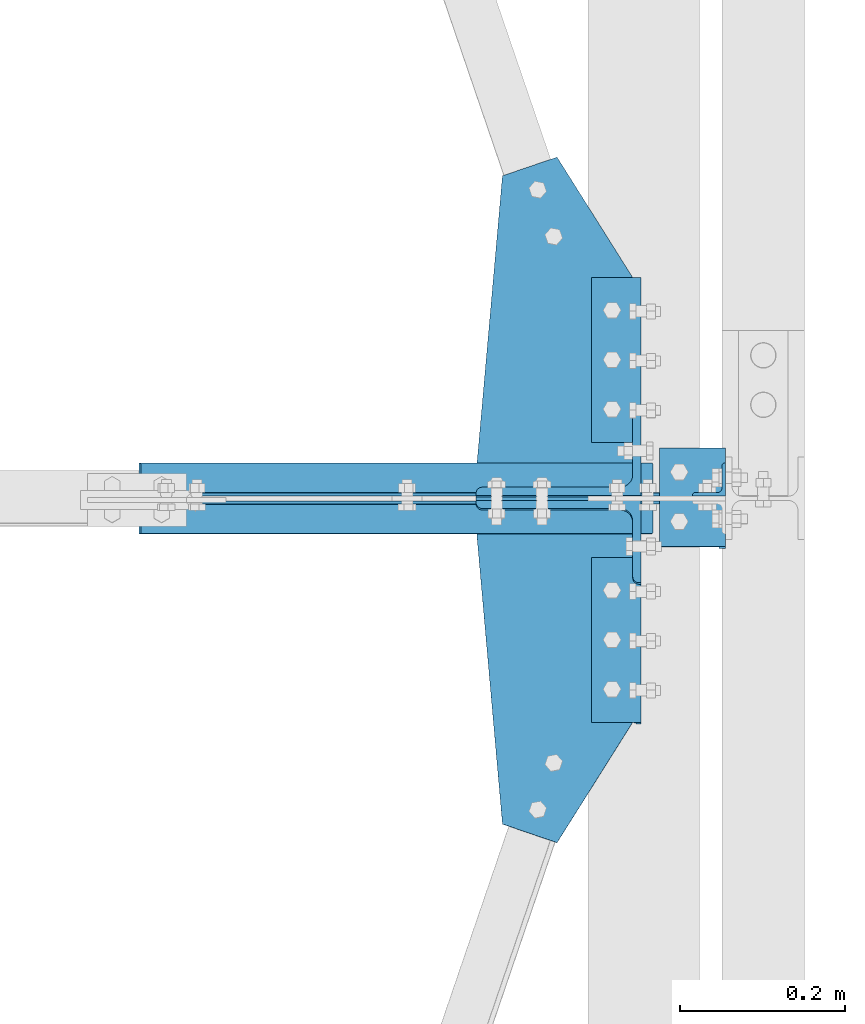
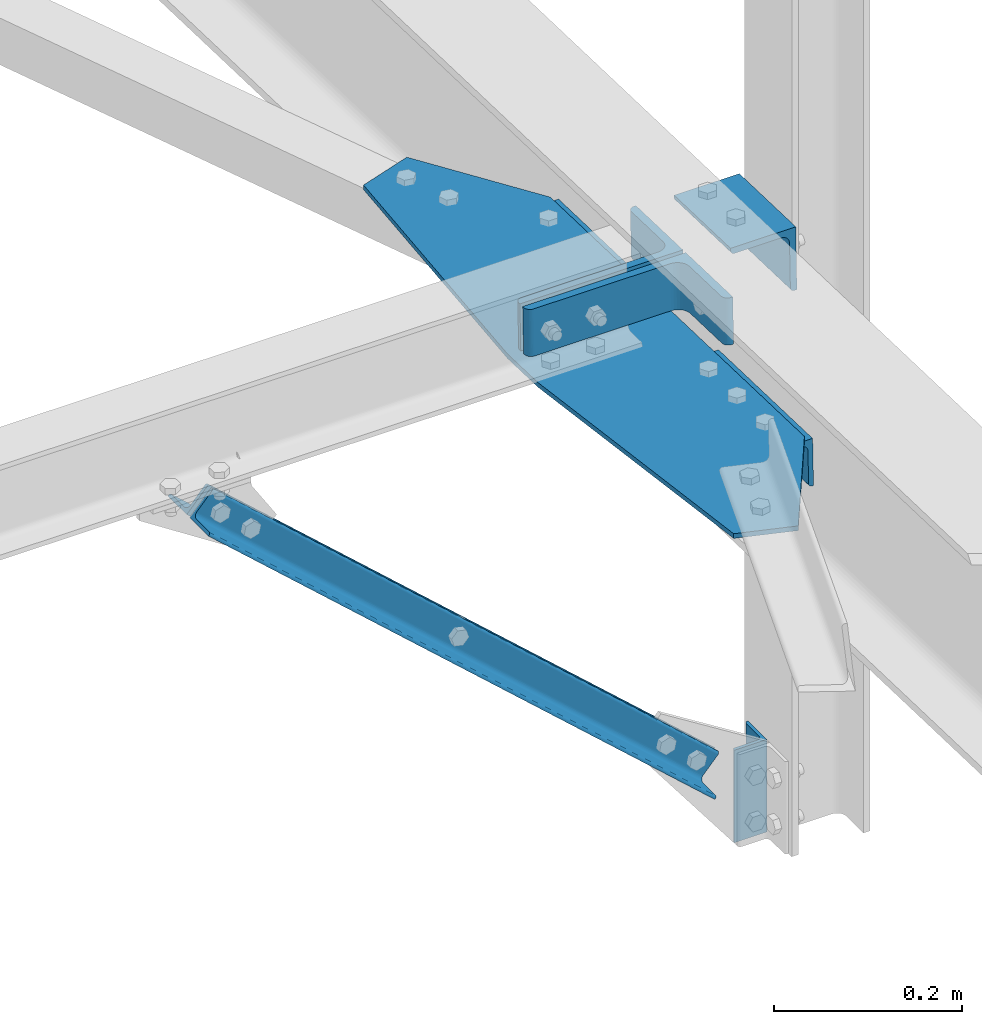
# One storey, part 107 of 496: 5 beams, 4 members, 9 elements without a shape of their own.
"""IFC2X3 building model written with IfcOpenShell, lengths in millimetres."""

import ifcopenshell
import ifcopenshell.guid

model = None  # the IFC model being written
_history = None  # IfcOwnerHistory: only IFC2X3 demands one
_inside = {}  # id of a spatial element -> (the spatial element, [elements in it])
_under = {}  # id of a project, library or spatial element -> (it, [spatial elements below it])
_declared = {}  # id of a project -> (the project, [libraries it declares])
_typed = {}  # id of a type object -> (the type object, [elements of that type])
_made_of = {}  # id of a material, layer set ... -> (it, [elements and type objects made of it])


def new_model(schema):
    """Start an empty IFC model of exactly this schema.

    Asked for "IFC4X3", IfcOpenShell would pick the latest addendum, in which some entities
    have other attributes; the version numbers below select the first issue.
    IFC2X3 requires an IfcOwnerHistory on every rooted entity: one is made here for all.
    """
    global model, _history
    if schema == "IFC4X3":
        model = ifcopenshell.file(schema_version=(4, 3, 0, 0))
    else:
        model = ifcopenshell.file(schema=schema)
    _inside.clear()
    _under.clear()
    _declared.clear()
    _typed.clear()
    _made_of.clear()
    _history = None
    if model.schema == "IFC2X3":
        org = make("IfcOrganization", Name="unknown")
        user = make(
            "IfcPersonAndOrganization",
            ThePerson=make("IfcPerson", FamilyName="unknown"),
            TheOrganization=org,
        )
        app = make(
            "IfcApplication",
            ApplicationDeveloper=org,
            Version="unknown",
            ApplicationFullName="unknown",
            ApplicationIdentifier="unknown",
        )
        _history = make(
            "IfcOwnerHistory",
            OwningUser=user,
            OwningApplication=app,
            ChangeAction="ADDED",
            CreationDate=0,
        )
    return model


def make(cls, **values):
    """One entity of the class cls with the attributes given. An attribute that is None is left unset."""
    return model.create_entity(
        cls, **{name: value for name, value in values.items() if value is not None}
    )


def rooted(cls, **values):
    """An entity with a GlobalId (a new one), such as an element, a storey or a relation."""
    return make(cls, GlobalId=ifcopenshell.guid.new(), OwnerHistory=_history, **values)


def si_unit(unit_type, name, prefix=None):
    """IfcSIUnit, for example si_unit("LENGTHUNIT", "METRE", prefix="MILLI")."""
    return make("IfcSIUnit", UnitType=unit_type, Prefix=prefix, Name=name)


def assignment(units):
    """IfcUnitAssignment: the units of a project."""
    return None if units is None else make("IfcUnitAssignment", Units=units)


def point(xyz):
    """IfcCartesianPoint."""
    return None if xyz is None else make("IfcCartesianPoint", Coordinates=xyz)


def direction(xyz):
    """IfcDirection."""
    return None if xyz is None else make("IfcDirection", DirectionRatios=xyz)


def frame(location, z_axis=None, x_axis=None):
    """IfcAxis2Placement3D, a coordinate frame: its origin and axes. An axis left out is left unset."""
    return make(
        "IfcAxis2Placement3D",
        Location=point(location),
        Axis=direction(z_axis),
        RefDirection=direction(x_axis),
    )


def frame_2d(location, x_axis=None):
    """IfcAxis2Placement2D, a coordinate frame in the plane: its origin and x axis."""
    return make(
        "IfcAxis2Placement2D", Location=point(location), RefDirection=direction(x_axis)
    )


def origin_with_axes():
    """The frame at (0, 0, 0) with the z axis (0, 0, 1) and the x axis (1, 0, 0) written out."""
    return frame((0.0, 0.0, 0.0), z_axis=(0.0, 0.0, 1.0), x_axis=(1.0, 0.0, 0.0))


def origin_2d_with_axis():
    """The frame at (0, 0) in the plane with the x axis (1, 0) written out."""
    return frame_2d((0.0, 0.0), x_axis=(1.0, 0.0))


def place(relative_to, where):
    """IfcLocalPlacement: puts the frame where relative to a parent placement (None: the world)."""
    return make(
        "IfcLocalPlacement", PlacementRelTo=relative_to, RelativePlacement=where
    )


def context(
    kind, dimensions, precision=None, world=None, true_north=None, identifier=None
):
    """IfcGeometricRepresentationContext, for example the 3D "Model" context."""
    return make(
        "IfcGeometricRepresentationContext",
        ContextIdentifier=identifier,
        ContextType=kind,
        CoordinateSpaceDimension=dimensions,
        Precision=precision,
        WorldCoordinateSystem=world,
        TrueNorth=true_north,
    )


def subcontext(parent, identifier, kind, view, scale=None):
    """IfcGeometricRepresentationSubContext, for example "Body" below "Model"."""
    return make(
        "IfcGeometricRepresentationSubContext",
        ContextIdentifier=identifier,
        ContextType=kind,
        ParentContext=parent,
        TargetScale=scale,
        TargetView=view,
    )


def project(units=None, contexts=None):
    """IfcProject with its units and contexts."""
    return rooted(
        "IfcProject",
        Name="project",
        RepresentationContexts=contexts,
        UnitsInContext=assignment(units),
    )


def spatial(cls, under=None, at=None, **own):
    """A site, building, storey or space (cls), placed at a placement, below another one or the project."""
    s = rooted(cls, ObjectPlacement=at, **own)
    if under is not None:
        _under.setdefault(under.id(), (under, []))[1].append(s)
    return s


def polyline(points):
    """IfcPolyline through the points."""
    return make("IfcPolyline", Points=[point(p) for p in points])


def profile(cls, at=None, kind="AREA", **sizes):
    """A parametric profile (cls). Its sizes go by their IFC names, for example OverallWidth=200.0."""
    return make(cls, ProfileType=kind, Position=at, **sizes)


def l_section(**sizes):
    """IfcLShapeProfileDef."""
    return profile("IfcLShapeProfileDef", **sizes)


def outline(outer, holes=None, kind="AREA"):
    """IfcArbitraryClosedProfileDef: a profile drawn as a closed curve; with holes, ...WithVoids."""
    if holes is None:
        return make("IfcArbitraryClosedProfileDef", ProfileType=kind, OuterCurve=outer)
    return make(
        "IfcArbitraryProfileDefWithVoids",
        ProfileType=kind,
        OuterCurve=outer,
        InnerCurves=holes,
    )


def extrude(swept, where, along, depth):
    """IfcExtrudedAreaSolid: the profile swept, set in the frame where, extruded along a direction by depth."""
    return make(
        "IfcExtrudedAreaSolid",
        SweptArea=swept,
        Position=where,
        ExtrudedDirection=direction(along),
        Depth=depth,
    )


def clip(a, b, op="DIFFERENCE"):
    """IfcBooleanClippingResult: the solid a cut by the half space b."""
    return make(
        "IfcBooleanClippingResult", Operator=op, FirstOperand=a, SecondOperand=b
    )


def halfspace(plane, agree):
    """IfcHalfSpaceSolid: all space on one side of the plane z = 0 of the frame plane."""
    return make(
        "IfcHalfSpaceSolid",
        BaseSurface=make("IfcPlane", Position=plane),
        AgreementFlag=agree,
    )


def shape(context_of_items, identifier, shape_type, items):
    """IfcShapeRepresentation: the items that make up one representation, for example the "Body"."""
    return make(
        "IfcShapeRepresentation",
        ContextOfItems=context_of_items,
        RepresentationIdentifier=identifier,
        RepresentationType=shape_type,
        Items=items,
    )


def material(Name=None, Category=None):
    """IfcMaterial."""
    return make("IfcMaterial", Name=Name, Category=Category)


def made_of(thing, what):
    """Note that an element or type object is made of a material, layer set ...; save() writes the relation."""
    if what is not None:
        _made_of.setdefault(what.id(), (what, []))[1].append(thing)
    return thing


def type_object(cls, material=None, **own):
    """A type object (cls), such as IfcWallType, which elements share."""
    return made_of(rooted(cls, **own), material)


def element(
    cls,
    number,
    at=None,
    inside=None,
    cuts=None,
    type_object=None,
    material=None,
    context=None,
    identifier="Body",
    shape_type=None,
    held_by="IfcProductDefinitionShape",
    body=None,
    shapes=None,
    **own,
):
    """One element of the class cls, such as IfcWall. Its Tag is "e" and its number.

    at: its placement. inside: the storey or other place that contains it. cuts: it is an
    opening in that element (IfcRelVoidsElement). A single representation is given by context,
    identifier, shape_type and body (its items); several are given by shapes. held_by: the class
    of the entity that holds the representations. save() writes the other relations.
    """
    e = rooted(cls, Tag="e%d" % number, ObjectPlacement=at, **own)
    if body is not None:
        shapes = [shape(context, identifier, shape_type, body)]
    if shapes is not None:
        e.Representation = make(held_by, Representations=shapes)
    if inside is not None:
        _inside.setdefault(inside.id(), (inside, []))[1].append(e)
    if cuts is not None:
        rooted(
            "IfcRelVoidsElement", RelatingBuildingElement=cuts, RelatedOpeningElement=e
        )
    if type_object is not None:
        _typed.setdefault(type_object.id(), (type_object, []))[1].append(e)
    return made_of(e, material)


def aggregate(whole, parts):
    """IfcRelAggregates: a whole, such as a stair, and the parts it consists of."""
    return rooted("IfcRelAggregates", RelatingObject=whole, RelatedObjects=parts)


def save(model, path):
    """Write the relations noted so far, then the file.

    IfcRelAggregates (storeys below a building ...), IfcRelContainedInSpatialStructure (elements
    in a storey), IfcRelDefinesByType, IfcRelAssociatesMaterial and IfcRelDeclares: one each for
    every whole, place, type object, material and project.
    """
    for whole, parts in _under.values():
        aggregate(whole, parts)
    for where, things in _inside.values():
        rooted(
            "IfcRelContainedInSpatialStructure",
            RelatedElements=things,
            RelatingStructure=where,
        )
    for kind, things in _typed.values():
        rooted("IfcRelDefinesByType", RelatedObjects=things, RelatingType=kind)
    for what, things in _made_of.values():
        rooted("IfcRelAssociatesMaterial", RelatedObjects=things, RelatingMaterial=what)
    for by, libraries in _declared.values():
        rooted("IfcRelDeclares", RelatingContext=by, RelatedDefinitions=libraries)
    model.write(path)


model = new_model("IFC2X3")

# Units and contexts
model_context = context("Model", 3, precision=1e-05, world=origin_with_axes())
body_context = subcontext(model_context, "Body", "Model", "MODEL_VIEW")
ifc_project = project(units=[si_unit("LENGTHUNIT", "METRE", prefix="MILLI"), si_unit("AREAUNIT", "SQUARE_METRE"), si_unit("VOLUMEUNIT", "CUBIC_METRE"), si_unit("MASSUNIT", "GRAM", prefix="KILO"), si_unit("TIMEUNIT", "SECOND"), si_unit("PLANEANGLEUNIT", "RADIAN"), si_unit("SOLIDANGLEUNIT", "STERADIAN"), si_unit("THERMODYNAMICTEMPERATUREUNIT", "DEGREE_CELSIUS"), si_unit("LUMINOUSINTENSITYUNIT", "LUMEN")], contexts=[model_context])

# Site, building, storey
site_placement = place(None, origin_with_axes())
site = spatial("IfcSite", under=ifc_project, at=site_placement, CompositionType="ELEMENT")
building_placement = place(site_placement, origin_with_axes())
building = spatial("IfcBuilding", under=site, at=building_placement, Name="Undefined", CompositionType="ELEMENT")
storey_placement = place(building_placement, origin_with_axes())
storey = spatial("IfcBuildingStorey", under=building, at=storey_placement, Name="Undefined", CompositionType="ELEMENT", Elevation=0.0)

# Assembly, beam
assembly_1_placement = place(storey_placement, origin_with_axes())
assembly_1 = element("IfcElementAssembly", 1, at=assembly_1_placement, inside=storey, AssemblyPlace="NOTDEFINED", PredefinedType="NOTDEFINED")
ifc_material = material(Name="Undefined/S235-E24")
beam_type_1 = type_object("IfcBeamType", PredefinedType="NOTDEFINED")
beam_1_placement = place(assembly_1_placement, frame((39596.4999999987, 3527.11779048528, 7783.07884358253), z_axis=(0.0, -0.031410887010906, -0.999506556345274), x_axis=(0.0, 0.999506556345274, -0.0314108870109058)))
beam_1 = element("IfcBeam", 2, at=beam_1_placement, type_object=beam_type_1, material=ifc_material, context=body_context, shape_type="SweptSolid", body=[
    extrude(l_section(Depth=60.0, Width=60.0, Thickness=6.0, FilletRadius=8.0, EdgeRadius=4.0, at=origin_2d_with_axis()), frame((200.0, 0.0, 0.0), z_axis=(-1.0, 0.0, 0.0), x_axis=(0.0, -1.0, 0.0)), (0.0, 0.0, 1.0), 200.0),
])
aggregate(assembly_1, [beam_1])

assembly_2_placement = place(storey_placement, origin_with_axes())
assembly_2 = element("IfcElementAssembly", 3, at=assembly_2_placement, inside=storey, AssemblyPlace="NOTDEFINED", PredefinedType="NOTDEFINED")
beam_2_placement = place(assembly_2_placement, frame((39596.4999999987, 3866.9500221617, 7772.3992222398), z_axis=(0.0, -0.031410887010906, -0.999506556345274), x_axis=(0.0, 0.999506556345274, -0.0314108870109058)))
beam_2 = element("IfcBeam", 4, at=beam_2_placement, type_object=beam_type_1, material=ifc_material, context=body_context, shape_type="SweptSolid", body=[
    extrude(l_section(Depth=60.0, Width=60.0, Thickness=6.0, FilletRadius=8.0, EdgeRadius=4.0, at=origin_2d_with_axis()), frame((200.0, 0.0, 0.0), z_axis=(-1.0, 0.0, 0.0), x_axis=(0.0, -1.0, 0.0)), (0.0, 0.0, 1.0), 200.0),
])
aggregate(assembly_2, [beam_2])

assembly_3_placement = place(storey_placement, origin_with_axes())
assembly_3 = element("IfcElementAssembly", 5, at=assembly_3_placement, inside=storey, AssemblyPlace="NOTDEFINED", PredefinedType="NOTDEFINED")
beam_type_2 = type_object("IfcBeamType", PredefinedType="NOTDEFINED")
beam_3_placement = place(assembly_3_placement, frame((39689.0, 3860.12744747542, 7878.46582542345), z_axis=(-1.0, 0.0, 0.0), x_axis=(0.0, -0.999506556345276, 0.031410887010852)))
beam_3 = element("IfcBeam", 6, at=beam_3_placement, type_object=beam_type_2, material=ifc_material, context=body_context, shape_type="SweptSolid", body=[
    extrude(l_section(Depth=80.0, Width=80.0, Thickness=8.0, FilletRadius=10.0, EdgeRadius=5.0, at=origin_2d_with_axis()), frame((120.0, 0.0, 0.0), z_axis=(-1.0, 0.0, 0.0), x_axis=(0.0, -1.0, 0.0)), (0.0, 0.0, 1.0), 120.0),
])
aggregate(assembly_3, [beam_3])

assembly_4_placement = place(storey_placement, origin_with_axes())
assembly_4 = element("IfcElementAssembly", 7, at=assembly_4_placement, inside=storey, AssemblyPlace="NOTDEFINED", PredefinedType="NOTDEFINED")
beam_type_3 = type_object("IfcBeamType", PredefinedType="NOTDEFINED")
beam_4_placement = place(assembly_4_placement, frame((39709.0000003665, 3823.0, 7220.00000925125), z_axis=(-1.0, 0.0, 0.0), x_axis=(0.0, 0.0, -1.0)))
beam_4 = element("IfcBeam", 8, at=beam_4_placement, type_object=beam_type_3, material=ifc_material, context=body_context, shape_type="SweptSolid", body=[
    extrude(l_section(Depth=40.0, Width=40.0, Thickness=4.0, FilletRadius=6.0, EdgeRadius=3.0, at=origin_2d_with_axis()), frame((120.0, 0.0, 0.0), z_axis=(-1.0, 0.0, 0.0), x_axis=(0.0, -1.0, 0.0)), (0.0, 0.0, 1.0), 120.0),
])
aggregate(assembly_4, [beam_4])

# Assembly, member
assembly_5_placement = place(storey_placement, origin_with_axes())
assembly_5 = element("IfcElementAssembly", 9, at=assembly_5_placement, inside=storey, AssemblyPlace="NOTDEFINED", PredefinedType="NOTDEFINED")
member_type_1 = type_object("IfcMemberType", PredefinedType="NOTDEFINED")
member_1_placement = place(assembly_5_placement, frame((39526.5, 3853.60293618613, 7888.87584319626), z_axis=(-1.0, 0.0, 0.0), x_axis=(0.0, -0.031410887010906, -0.999506556345274)))
member_1 = element("IfcMember", 10, at=member_1_placement, type_object=member_type_1, material=ifc_material, context=body_context, shape_type="SweptSolid", body=[
    extrude(l_section(Depth=200.0, Width=100.0, Thickness=10.0, FilletRadius=15.0, EdgeRadius=7.5, at=origin_2d_with_axis()), frame((60.0, 0.0, 0.0), z_axis=(-1.0, 0.0, 0.0), x_axis=(0.0, -1.0, 0.0)), (0.0, 0.0, 1.0), 60.0),
])
aggregate(assembly_5, [member_1])

assembly_6_placement = place(storey_placement, origin_with_axes())
assembly_6 = element("IfcElementAssembly", 11, at=assembly_6_placement, inside=storey, AssemblyPlace="NOTDEFINED", PredefinedType="NOTDEFINED")
member_2_placement = place(assembly_6_placement, frame((39526.4999999999, 3745.7696853425, 7832.2351062107), z_axis=(-1.0, 0.0, 0.0), x_axis=(0.0, 0.031410887010906, 0.999506556345274)))
member_2 = element("IfcMember", 12, at=member_2_placement, type_object=member_type_1, material=ifc_material, context=body_context, shape_type="SweptSolid", body=[
    extrude(l_section(Depth=200.0, Width=100.0, Thickness=10.0, FilletRadius=15.0, EdgeRadius=7.5, at=origin_2d_with_axis()), frame((60.0, 0.0, 0.0), z_axis=(-1.0, 0.0, 0.0), x_axis=(0.0, -1.0, 0.0)), (0.0, 0.0, 1.0), 60.0),
])
aggregate(assembly_6, [member_2])

# Assembly, beam
assembly_7_placement = place(storey_placement, origin_with_axes())
assembly_7 = element("IfcElementAssembly", 13, at=assembly_7_placement, inside=storey, AssemblyPlace="NOTDEFINED", PredefinedType="NOTDEFINED")
beam_type_4 = type_object("IfcBeamType", PredefinedType="NOTDEFINED")
beam_5_placement = place(assembly_7_placement, frame((39524.7284665203, 4213.86039998705, 7794.51337791409), z_axis=(0.0, 0.031410887010906, 0.999506556345274), x_axis=(-0.946212755104547, -0.323385430448102, 0.0101629450140826)))
beam_5 = element("IfcBeam", 14, at=beam_5_placement, type_object=beam_type_4, material=ifc_material, context=body_context, shape_type="SweptSolid", body=[
    extrude(outline(polyline([(0.0, 0.0), (70.0, 0.0), (217.200622562639, 331.60662841788), (237.907470707731, 392.164245605225), (324.563232429304, 744.475158689993), (269.218597419203, 787.33502197061), (135.130676274654, 678.836425778762), (-39.5834617609507, 167.881454466617), (0.0, 0.0)])), frame((0.0, 0.0, -3.0), z_axis=(0.0, 0.0, 1.0), x_axis=(1.0, 0.0, 0.0)), (0.0, 0.0, 1.0), 6.0),
])
aggregate(assembly_7, [beam_5])

# Assembly, member
assembly_8_placement = place(storey_placement, origin_with_axes())
assembly_8 = element("IfcElementAssembly", 15, at=assembly_8_placement, inside=storey, AssemblyPlace="NOTDEFINED", PredefinedType="NOTDEFINED")
member_type_2 = type_object("IfcMemberType", PredefinedType="NOTDEFINED")
member_3_placement = place(assembly_8_placement, frame((38993.6621590046, 3777.00038405552, 7809.03427808132), z_axis=(0.668920493863177, 0.0, 0.743333957847914), x_axis=(0.743333959737309, 0.0, -0.668920491763597)))
member_3 = element("IfcMember", 16, at=member_3_placement, type_object=member_type_2, material=ifc_material, context=body_context, shape_type="Clipping", body=[
    clip(clip(extrude(l_section(Depth=40.0, Width=40.0, Thickness=4.0, FilletRadius=6.0, EdgeRadius=3.0, at=origin_2d_with_axis()), frame((925.809947913334, 0.0, 0.0), z_axis=(-1.0, 0.0, 0.0), x_axis=(0.0, -1.0, 0.0)), (0.0, 0.0, 1.0), 915.99), halfspace(frame((885.633657403443, 22.9996159444818, 20.0000000006185), z_axis=(-1.0, 0.0, 0.0), x_axis=(0.0, -1.0, 0.0)), True)), halfspace(frame((50.0000000000509, 22.9996159444818, 20.0000000006221), z_axis=(-1.0, 0.0, 0.0), x_axis=(0.0, -1.0, 0.0)), False)),
])
aggregate(assembly_8, [member_3])

assembly_9_placement = place(storey_placement, origin_with_axes())
assembly_9 = element("IfcElementAssembly", 17, at=assembly_9_placement, inside=storey, AssemblyPlace="NOTDEFINED", PredefinedType="NOTDEFINED")
member_4_placement = place(assembly_9_placement, frame((39727.6621590179, 3823.00038408325, 7148.51334140001), z_axis=(0.668920493863177, 0.0, 0.743333957847914), x_axis=(-0.743333957847914, 0.0, 0.668920493863177)))
member_4 = element("IfcMember", 18, at=member_4_placement, type_object=member_type_2, material=ifc_material, context=body_context, shape_type="Clipping", body=[
    clip(clip(extrude(l_section(Depth=40.0, Width=40.0, Thickness=4.0, FilletRadius=6.0, EdgeRadius=3.0, at=origin_2d_with_axis()), frame((977.619406751979, 4.54747350886464e-13, 0.0), z_axis=(-1.0, 0.0, 0.0), x_axis=(0.0, -1.0, 0.0)), (0.0, 0.0, 1.0), 915.99), halfspace(frame((937.443116242081, 23.0003840832474, 19.9999996008664), z_axis=(1.0, 0.0, 0.0), x_axis=(0.0, 1.0, 0.0)), False)), halfspace(frame((101.809458838688, 23.0003840832474, 19.9999996008628), z_axis=(1.0, 0.0, 0.0), x_axis=(0.0, 1.0, 0.0)), True)),
])
aggregate(assembly_9, [member_4])

save(model, "model.ifc")
